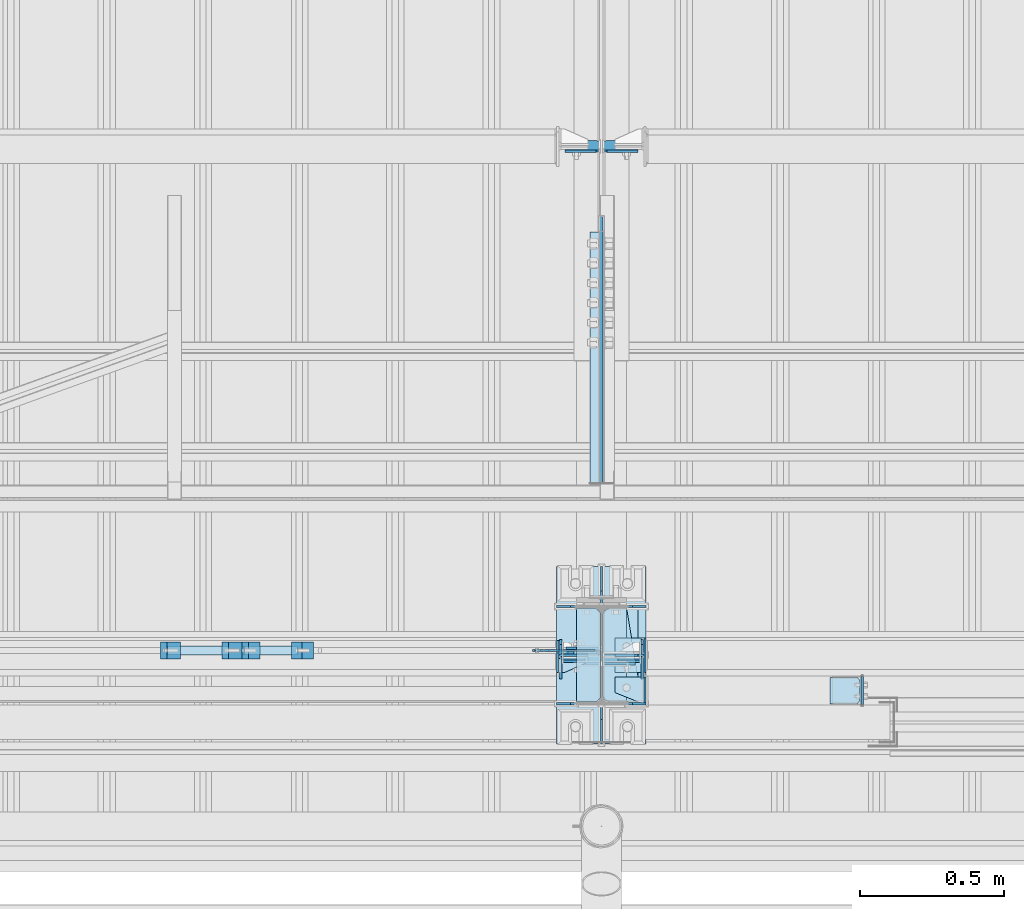
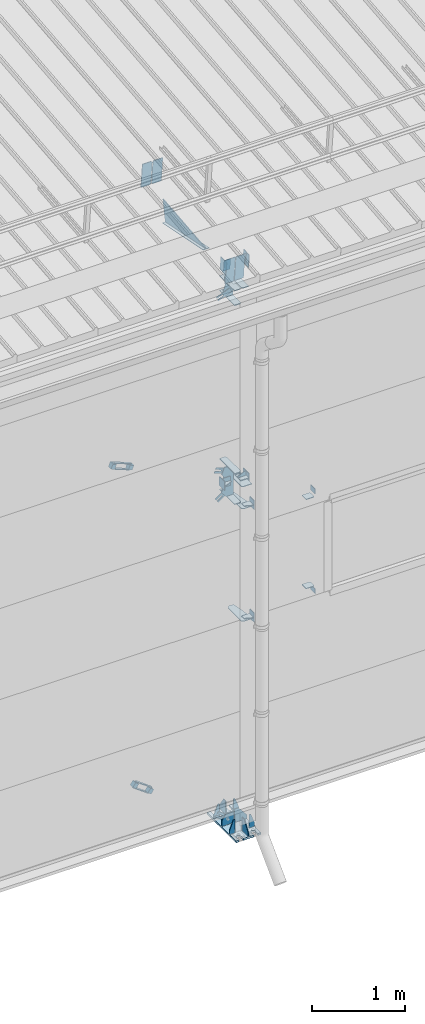
# One storey, part 125 of 709: 55 plates, 4 openings, 15 elements without a shape of their own.
"""IFC4 building model written with IfcOpenShell, lengths in millimetres."""

from ifc_helpers import new_model, si_unit, direction, frame, origin_with_axes, place, context, subcontext, project, spatial, line, arc, indexed_curve, outline, extrude, material, element, aggregate, save


model = new_model("IFC4")

# Units and contexts
model_context = context("Model", 3, precision=0.2, world=origin_with_axes(), true_north=direction((0.0, 1.0)))
body_context = subcontext(model_context, "Body", "Model", "MODEL_VIEW")
ifc_project = project(units=[si_unit("LENGTHUNIT", "METRE", prefix="MILLI"), si_unit("AREAUNIT", "SQUARE_METRE"), si_unit("VOLUMEUNIT", "CUBIC_METRE"), si_unit("MASSUNIT", "GRAM", prefix="KILO"), si_unit("TIMEUNIT", "SECOND"), si_unit("PLANEANGLEUNIT", "RADIAN"), si_unit("SOLIDANGLEUNIT", "STERADIAN"), si_unit("THERMODYNAMICTEMPERATUREUNIT", "DEGREE_CELSIUS"), si_unit("LUMINOUSINTENSITYUNIT", "LUMEN")], contexts=[model_context])

# Site, building, storey
site_placement = place(None, origin_with_axes())
site = spatial("IfcSite", under=ifc_project, at=site_placement, CompositionType="ELEMENT")
building_placement = place(site_placement, origin_with_axes())
building = spatial("IfcBuilding", under=site, at=building_placement, Name="Undefined", CompositionType="ELEMENT")
storey_placement = place(building_placement, origin_with_axes())
storey = spatial("IfcBuildingStorey", under=building, at=storey_placement, Name="Undefined", CompositionType="ELEMENT", Elevation=0.0)

# Assembly, plates
assembly_1_placement = place(storey_placement, frame((28000.0, 346.0, 7089.70002), z_axis=(1.0, 0.0, 0.0), x_axis=(0.0, 0.9950371902, 0.099503719)))
assembly_1 = element("IfcElementAssembly", 1, at=assembly_1_placement, inside=storey)
ifc_material_1 = material(Name="C355-6", Category="STEEL")
plate_1_placement = place(assembly_1_placement, frame((1597.88359, 163.0, 127.0), z_axis=(-1.0, 0.0, 0.0), x_axis=(0.0, 0.0, -1.0)))
plate_1 = element("IfcPlate", 2, at=plate_1_placement, material=ifc_material_1, ObjectType="585", context=body_context, shape_type="SolidModel", body=[
    extrude(outline(indexed_curve([(0.0, 0.0), (108.0, 0.0), (123.0, 15.0), (123.0, 311.0), (108.0, 326.0), (0.0, 326.0)], segments=[line(1, 2, 3, 4, 5, 6, 1)])), frame((0.0, 0.0, 4.0), z_axis=(0.0, 0.0, 1.0), x_axis=(1.0, 0.0, 0.0)), (0.0, 0.0, -1.0), 8.0),
])
plate_2_placement = place(assembly_1_placement, frame((1597.88359, 163.0, -127.0), z_axis=(1.0, 0.0, 0.0), x_axis=(0.0, 0.0, 1.0)))
plate_2 = element("IfcPlate", 3, at=plate_2_placement, material=ifc_material_1, ObjectType="585", context=body_context, shape_type="SolidModel", body=[
    extrude(outline(indexed_curve([(0.0, 0.0), (108.0, 0.0), (123.0, 15.0), (123.0, 311.0), (108.0, 326.0), (0.0, 326.0)], segments=[line(1, 2, 3, 4, 5, 6, 1)])), frame((0.0, 0.0, 4.0), z_axis=(0.0, 0.0, 1.0), x_axis=(1.0, 0.0, 0.0)), (0.0, 0.0, -1.0), 8.0),
])
plate_3_placement = place(assembly_1_placement, frame((1255.8048, -434.94249, -40.0), z_axis=(0.2927142719, 0.9561999556, 0.0), x_axis=(-0.9561999556, 0.2927142719, 0.0)))
plate_3 = element("IfcPlate", 4, at=plate_3_placement, material=ifc_material_1, ObjectType="450", context=body_context, shape_type="SolidModel", body=[
    extrude(outline(indexed_curve([(0.0, 0.0), (887.65935, 0.0), (887.65935, 80.0), (0.0, 80.0)], segments=[line(1, 2, 3, 4, 1)])), frame((0.0, 0.0, 4.0), z_axis=(0.0, 0.0, 1.0), x_axis=(1.0, 0.0, 0.0)), (0.0, 0.0, -1.0), 8.0),
])
plate_4_placement = place(assembly_1_placement, frame((1336.51563, -171.28713, 0.0), z_axis=(0.0, 0.0, 1.0), x_axis=(-1.0, 0.0, 0.0)))
plate_4 = element("IfcPlate", 5, at=plate_4_placement, material=ifc_material_1, ObjectType="449", context=body_context, shape_type="SolidModel", body=[
    extrude(outline(indexed_curve([(0.0, 0.0), (928.3198, 0.0), (79.53997, 259.83056)], segments=[line(1, 2, 3, 1)])), frame((0.0, 0.0, 6.0), z_axis=(0.0, 0.0, 1.0), x_axis=(1.0, 0.0, 0.0)), (0.0, 0.0, -1.0), 12.0),
])
aggregate(assembly_1, [plate_1, plate_2, plate_3, plate_4])

assembly_2_placement = place(storey_placement, frame((22000.0, 173.0, 4310.0), z_axis=(0.0, 0.0, -1.0), x_axis=(1.0, 0.0, 0.0)))
assembly_2 = element("IfcElementAssembly", 6, at=assembly_2_placement, inside=storey)
plate_5_placement = place(assembly_2_placement, frame((5953.0, 60.0, 0.0), z_axis=(0.0, 0.0, -1.0), x_axis=(0.0, -1.0, 0.0)))
plate_5 = element("IfcPlate", 7, at=plate_5_placement, material=ifc_material_1, ObjectType="521", context=body_context, shape_type="SolidModel", body=[
    extrude(outline(indexed_curve([(0.0, 80.0), (36.0, 0.0), (56.0, 0.0), (56.0, 90.0), (46.0, 100.0), (0.0, 100.0)], segments=[line(1, 2, 3, 4, 5, 6, 1)])), frame((0.0, 0.0, 4.0), z_axis=(0.0, 0.0, 1.0), x_axis=(1.0, 0.0, 0.0)), (0.0, 0.0, -1.0), 8.0),
])
plate_6_placement = place(assembly_2_placement, frame((5953.0, 0.0, -60.0), z_axis=(0.0, -1.0, 0.0), x_axis=(0.0, 0.0, 1.0)))
plate_6 = element("IfcPlate", 8, at=plate_6_placement, material=ifc_material_1, ObjectType="520", context=body_context, shape_type="SolidModel", body=[
    extrude(outline(indexed_curve([(0.0, 0.0), (120.0, 0.0), (120.0, 100.0), (0.0, 100.0)], segments=[line(1, 2, 3, 4, 1)])), frame((0.0, 0.0, 4.0), z_axis=(0.0, 0.0, 1.0), x_axis=(1.0, 0.0, 0.0)), (0.0, 0.0, -1.0), 8.0),
])
plate_7_placement = place(assembly_2_placement, frame((5849.0, -50.0, -60.0), z_axis=(1.0, 0.0, 0.0), x_axis=(0.0, 1.0, 0.0)))
plate_7 = element("IfcPlate", 9, at=plate_7_placement, material=ifc_material_1, ObjectType="519", context=body_context, shape_type="SolidModel", body=[
    extrude(outline(indexed_curve([(0.0, 0.0), (110.0, 0.0), (110.0, 120.0), (0.0, 120.0)], segments=[line(1, 2, 3, 4, 1)])), frame((0.0, 0.0, 4.0), z_axis=(0.0, 0.0, 1.0), x_axis=(1.0, 0.0, 0.0)), (0.0, 0.0, -1.0), 8.0),
])
aggregate(assembly_2, [plate_5, plate_6, plate_7])

# Assembly, plate
assembly_3_placement = place(storey_placement, frame((23129.07626, 189.0, 672.76012), z_axis=(0.0, -1.0, 0.0), x_axis=(0.8064830392, 0.0, 0.5912572262)))
assembly_3 = element("IfcElementAssembly", 10, at=assembly_3_placement, inside=storey)
plate_8_placement = place(assembly_3_placement, frame((5781.83429, 35.0, 0.0), z_axis=(0.0, 0.0, -1.0), x_axis=(1.0, 0.0, 0.0)))
plate_8 = element("IfcPlate", 11, at=plate_8_placement, material=ifc_material_1, ObjectType="525", context=body_context, shape_type="SolidModel", body=[
    extrude(outline(indexed_curve([(0.0, 0.0), (200.0, 0.0), (200.0, 70.0), (0.0, 70.0), (0.0, 46.0), (80.0, 46.0), (80.0, 24.0), (0.0, 24.0)], segments=[line(1, 2, 3, 4, 5, 6, 7, 8, 1)])), frame((0.0, 0.0, 4.0), z_axis=(0.0, 0.0, 1.0), x_axis=(1.0, 0.0, 0.0)), (0.0, 0.0, -1.0), 8.0),
])
aggregate(assembly_3, [plate_8])

assembly_4_placement = place(storey_placement, frame((26870.92374, 189.0, 672.76012), z_axis=(0.0, -1.0, 0.0), x_axis=(0.8064830392, 0.0, -0.5912572261)))
assembly_4 = element("IfcElementAssembly", 12, at=assembly_4_placement, inside=storey)
plate_9_placement = place(assembly_4_placement, frame((1145.82155, 11.0, 0.0), z_axis=(0.0, 0.0, 1.0), x_axis=(1.0, 0.0, 0.0)))
plate_9 = element("IfcPlate", 13, at=plate_9_placement, material=ifc_material_1, ObjectType="490", context=body_context, shape_type="SolidModel", body=[
    extrude(outline(indexed_curve([(0.0, 0.0), (80.0, 0.0), (80.0, -22.0), (0.0, -22.0), (0.0, -46.0), (200.0, -46.0), (200.0, 24.0), (0.0, 24.0)], segments=[line(1, 2, 3, 4, 5, 6, 7, 8, 1)])), frame((0.0, 0.0, 4.0), z_axis=(0.0, 0.0, 1.0), x_axis=(1.0, 0.0, 0.0)), (0.0, 0.0, -1.0), 8.0),
])
aggregate(assembly_4, [plate_9])

# Assembly, plates
assembly_5_placement = place(storey_placement, frame((26981.40701, 159.0, 628.96003), z_axis=(-0.8064830392, 0.0, 0.5912572262), x_axis=(0.0, 1.0, 0.0)))
assembly_5 = element("IfcElementAssembly", 14, at=assembly_5_placement, inside=storey)
ifc_material_2 = material(Name="Steel_Undefined", Category="STEEL")
plate_10_placement = place(assembly_5_placement, frame((0.0, 0.0, 230.0), z_axis=(0.0, 0.0, 1.0), x_axis=(1.0, 0.0, 0.0)))
plate_10 = element("IfcPlate", 15, at=plate_10_placement, material=ifc_material_2, ObjectType="483", context=body_context, shape_type="SolidModel", body=[
    extrude(outline(indexed_curve([(0.0, 0.0), (60.0, 0.0), (60.0, 60.0), (0.0, 60.0)], segments=[line(1, 2, 3, 4, 1)])), frame((0.0, 0.0, 25.0), z_axis=(0.0, 0.0, 1.0), x_axis=(1.0, 0.0, 0.0)), (0.0, 0.0, -1.0), 50.0),
])
plate_11_placement = place(assembly_5_placement, frame((15.0, -6.0, 230.0), z_axis=(0.0, 1.0, 0.0), x_axis=(1.0, 0.0, 0.0)))
plate_11 = element("IfcPlate", 16, at=plate_11_placement, material=ifc_material_2, ObjectType="484", context=body_context, shape_type="SolidModel", body=[
    extrude(outline(indexed_curve([(0.0, 0.0), (30.0, 0.0), (30.0, 230.0), (0.0, 230.0)], segments=[line(1, 2, 3, 4, 1)])), frame((0.0, 0.0, 6.0), z_axis=(0.0, 0.0, 1.0), x_axis=(1.0, 0.0, 0.0)), (0.0, 0.0, -1.0), 12.0),
])
plate_12_placement = place(assembly_5_placement, frame((15.0, 66.0, 230.0), z_axis=(0.0, 1.0, 0.0), x_axis=(1.0, 0.0, 0.0)))
plate_12 = element("IfcPlate", 17, at=plate_12_placement, material=ifc_material_2, ObjectType="484", context=body_context, shape_type="SolidModel", body=[
    extrude(outline(indexed_curve([(0.0, 0.0), (30.0, 0.0), (30.0, 230.0), (0.0, 230.0)], segments=[line(1, 2, 3, 4, 1)])), frame((0.0, 0.0, 6.0), z_axis=(0.0, 0.0, 1.0), x_axis=(1.0, 0.0, 0.0)), (0.0, 0.0, -1.0), 12.0),
])
plate_13_placement = place(assembly_5_placement, origin_with_axes())
plate_13 = element("IfcPlate", 18, at=plate_13_placement, material=ifc_material_2, ObjectType="482", context=body_context, shape_type="SolidModel", body=[
    extrude(outline(indexed_curve([(0.0, 0.0), (60.0, 0.0), (60.0, 60.0), (0.0, 60.0)], segments=[line(1, 2, 3, 4, 1)])), frame((0.0, 0.0, 25.0), z_axis=(0.0, 0.0, 1.0), x_axis=(1.0, 0.0, 0.0)), (0.0, 0.0, -1.0), 50.0),
])
aggregate(assembly_5, [plate_10, plate_11, plate_12, plate_13])

# Assembly, plate
assembly_6_placement = place(storey_placement, frame((23387.0491, 189.0, 4959.49238), z_axis=(0.0, -1.0, 0.0), x_axis=(0.9286065, 0.0, 0.371065989)))
assembly_6 = element("IfcElementAssembly", 19, at=assembly_6_placement, inside=storey)
plate_14_placement = place(assembly_6_placement, frame((4750.84953, 11.0, 0.0), z_axis=(0.0, 0.0, 1.0), x_axis=(1.0, 0.0, 0.0)))
plate_14 = element("IfcPlate", 20, at=plate_14_placement, material=ifc_material_1, ObjectType="556", context=body_context, shape_type="SolidModel", body=[
    extrude(outline(indexed_curve([(0.0, 0.0), (80.0, 0.0), (80.0, -22.0), (0.0, -22.0), (0.0, -41.0), (180.0, -41.0), (180.0, 19.0), (0.0, 19.0)], segments=[line(1, 2, 3, 4, 5, 6, 7, 8, 1)])), frame((0.0, 0.0, 4.0), z_axis=(0.0, 0.0, 1.0), x_axis=(1.0, 0.0, 0.0)), (0.0, 0.0, -1.0), 8.0),
])
aggregate(assembly_6, [plate_14])

assembly_7_placement = place(storey_placement, frame((26612.9509, 189.0, 4959.49238), z_axis=(0.0, -1.0, 0.0), x_axis=(0.9286065, 0.0, -0.371065989)))
assembly_7 = element("IfcElementAssembly", 21, at=assembly_7_placement, inside=storey)
plate_15_placement = place(assembly_7_placement, frame((1250.0, 35.0, 0.0), z_axis=(0.0, 0.0, -1.0), x_axis=(1.0, 0.0, 0.0)))
plate_15 = element("IfcPlate", 22, at=plate_15_placement, material=ifc_material_1, ObjectType="525", context=body_context, shape_type="SolidModel", body=[
    extrude(outline(indexed_curve([(0.0, 0.0), (200.0, 0.0), (200.0, 70.0), (0.0, 70.0), (0.0, 46.0), (80.0, 46.0), (80.0, 24.0), (0.0, 24.0)], segments=[line(1, 2, 3, 4, 5, 6, 7, 8, 1)])), frame((0.0, 0.0, 4.0), z_axis=(0.0, 0.0, 1.0), x_axis=(1.0, 0.0, 0.0)), (0.0, 0.0, -1.0), 8.0),
])
aggregate(assembly_7, [plate_15])

# Assembly, plates
assembly_8_placement = place(storey_placement, frame((26730.87263, 159.0, 4944.67799), z_axis=(-0.9286065, 0.0, 0.371065989), x_axis=(0.0, 1.0, 0.0)))
assembly_8 = element("IfcElementAssembly", 23, at=assembly_8_placement, inside=storey)
plate_16_placement = place(assembly_8_placement, origin_with_axes())
plate_16 = element("IfcPlate", 24, at=plate_16_placement, material=ifc_material_2, ObjectType="482", context=body_context, shape_type="SolidModel", body=[
    extrude(outline(indexed_curve([(0.0, 0.0), (60.0, 0.0), (60.0, 60.0), (0.0, 60.0)], segments=[line(1, 2, 3, 4, 1)])), frame((0.0, 0.0, 25.0), z_axis=(0.0, 0.0, 1.0), x_axis=(1.0, 0.0, 0.0)), (0.0, 0.0, -1.0), 50.0),
])
plate_17_placement = place(assembly_8_placement, frame((0.0, 0.0, 230.0), z_axis=(0.0, 0.0, 1.0), x_axis=(1.0, 0.0, 0.0)))
plate_17 = element("IfcPlate", 25, at=plate_17_placement, material=ifc_material_2, ObjectType="483", context=body_context, shape_type="SolidModel", body=[
    extrude(outline(indexed_curve([(0.0, 0.0), (60.0, 0.0), (60.0, 60.0), (0.0, 60.0)], segments=[line(1, 2, 3, 4, 1)])), frame((0.0, 0.0, 25.0), z_axis=(0.0, 0.0, 1.0), x_axis=(1.0, 0.0, 0.0)), (0.0, 0.0, -1.0), 50.0),
])
plate_18_placement = place(assembly_8_placement, frame((15.0, 66.0, 230.0), z_axis=(0.0, 1.0, 0.0), x_axis=(1.0, 0.0, 0.0)))
plate_18 = element("IfcPlate", 26, at=plate_18_placement, material=ifc_material_2, ObjectType="484", context=body_context, shape_type="SolidModel", body=[
    extrude(outline(indexed_curve([(0.0, 0.0), (30.0, 0.0), (30.0, 230.0), (0.0, 230.0)], segments=[line(1, 2, 3, 4, 1)])), frame((0.0, 0.0, 6.0), z_axis=(0.0, 0.0, 1.0), x_axis=(1.0, 0.0, 0.0)), (0.0, 0.0, -1.0), 12.0),
])
plate_19_placement = place(assembly_8_placement, frame((15.0, -6.0, 230.0), z_axis=(0.0, 1.0, 0.0), x_axis=(1.0, 0.0, 0.0)))
plate_19 = element("IfcPlate", 27, at=plate_19_placement, material=ifc_material_2, ObjectType="484", context=body_context, shape_type="SolidModel", body=[
    extrude(outline(indexed_curve([(0.0, 0.0), (30.0, 0.0), (30.0, 230.0), (0.0, 230.0)], segments=[line(1, 2, 3, 4, 1)])), frame((0.0, 0.0, 6.0), z_axis=(0.0, 0.0, 1.0), x_axis=(1.0, 0.0, 0.0)), (0.0, 0.0, -1.0), 12.0),
])
aggregate(assembly_8, [plate_16, plate_17, plate_18, plate_19])

# Assembly, plates, voiding features
assembly_9_placement = place(storey_placement, frame((28000.0, 173.0, -200.0), z_axis=(-1.0, 0.0, 0.0), x_axis=(0.0, 0.0, 1.0)))
assembly_9 = element("IfcElementAssembly", 28, at=assembly_9_placement, inside=storey)
plate_20_placement = place(assembly_9_placement, frame((7434.21546, -30.02526, -3.0), z_axis=(0.099503719, 0.9950371902, 0.0), x_axis=(0.0, 0.0, -1.0)))
plate_20 = element("IfcPlate", 29, at=plate_20_placement, material=ifc_material_1, ObjectType="595", context=body_context, shape_type="SolidModel", body=[
    extrude(outline(indexed_curve([(0.0, 0.0), (114.0, 0.0), (114.0, 332.53554), (0.0, 332.53554)], segments=[line(1, 2, 3, 4, 1)])), frame((0.0, 0.0, 4.0), z_axis=(0.0, 0.0, 1.0), x_axis=(1.0, 0.0, 0.0)), (0.0, 0.0, -1.0), 8.0),
])
plate_21_placement = place(assembly_9_placement, frame((7434.21546, -30.02526, 3.0), z_axis=(-0.099503719, -0.9950371902, 0.0), x_axis=(0.0, 0.0, 1.0)))
plate_21 = element("IfcPlate", 30, at=plate_21_placement, material=ifc_material_1, ObjectType="595", context=body_context, shape_type="SolidModel", body=[
    extrude(outline(indexed_curve([(0.0, 0.0), (114.0, 0.0), (114.0, 333.33554), (0.0, 333.33554)], segments=[line(1, 2, 3, 4, 1)])), frame((0.0, 0.0, 4.0), z_axis=(0.0, 0.0, 1.0), x_axis=(1.0, 0.0, 0.0)), (0.0, 0.0, -1.0), 8.0),
])
plate_22_placement = place(assembly_9_placement, frame((6906.03718, 163.0, 87.0), z_axis=(-1.0, 0.0, 0.0), x_axis=(0.0, 0.0, -1.0)))
plate_22 = element("IfcPlate", 31, at=plate_22_placement, material=ifc_material_1, ObjectType="461", context=body_context, shape_type="SolidModel", body=[
    extrude(outline(indexed_curve([(0.0, 0.0), (68.0, 0.0), (83.0, 15.0), (83.0, 311.0), (68.0, 326.0), (0.0, 326.0)], segments=[line(1, 2, 3, 4, 5, 6, 1)])), frame((0.0, 0.0, 4.0), z_axis=(0.0, 0.0, 1.0), x_axis=(1.0, 0.0, 0.0)), (0.0, 0.0, -1.0), 8.0),
])
plate_23_placement = place(assembly_9_placement, frame((7097.93718, 163.0, 87.0), z_axis=(-1.0, 0.0, 0.0), x_axis=(0.0, 0.0, -1.0)))
plate_23 = element("IfcPlate", 32, at=plate_23_placement, material=ifc_material_1, ObjectType="461", context=body_context, shape_type="SolidModel", body=[
    extrude(outline(indexed_curve([(0.0, 0.0), (68.0, 0.0), (83.0, 15.0), (83.0, 311.0), (68.0, 326.0), (0.0, 326.0)], segments=[line(1, 2, 3, 4, 5, 6, 1)])), frame((0.0, 0.0, 4.0), z_axis=(0.0, 0.0, 1.0), x_axis=(1.0, 0.0, 0.0)), (0.0, 0.0, -1.0), 8.0),
])
plate_24_placement = place(assembly_9_placement, frame((7097.93718, -163.0, -87.0), z_axis=(-1.0, 0.0, 0.0), x_axis=(0.0, 0.0, 1.0)))
plate_24 = element("IfcPlate", 33, at=plate_24_placement, material=ifc_material_1, ObjectType="461", context=body_context, shape_type="SolidModel", body=[
    extrude(outline(indexed_curve([(0.0, 0.0), (68.0, 0.0), (83.0, 15.0), (83.0, 311.0), (68.0, 326.0), (0.0, 326.0)], segments=[line(1, 2, 3, 4, 5, 6, 1)])), frame((0.0, 0.0, 4.0), z_axis=(0.0, 0.0, 1.0), x_axis=(1.0, 0.0, 0.0)), (0.0, 0.0, -1.0), 8.0),
])
plate_25_placement = place(assembly_9_placement, frame((25.0, 0.0, -3.0), z_axis=(0.0, -1.0, 0.0), x_axis=(0.0, 0.0, -1.0)))
plate_25 = element("IfcPlate", 34, at=plate_25_placement, material=ifc_material_1, ObjectType="417", context=body_context, shape_type="SolidModel", body=[
    extrude(outline(indexed_curve([(0.0, 0.0), (152.0, 0.0), (152.0, 50.0), (50.0, 175.0), (0.0, 175.0)], segments=[line(1, 2, 3, 4, 5, 1)])), frame((0.0, 0.0, 4.0), z_axis=(0.0, 0.0, 1.0), x_axis=(1.0, 0.0, 0.0)), (0.0, 0.0, -1.0), 8.0),
])
plate_26_placement = place(assembly_9_placement, frame((12.5, -308.0, 155.0), z_axis=(1.0, 0.0, 0.0), x_axis=(0.0, 0.0, -1.0)))
plate_26 = element("IfcPlate", 35, at=plate_26_placement, material=ifc_material_1, context=body_context, shape_type="SolidModel", body=[
    extrude(outline(indexed_curve([(0.0, 0.0), (310.0, 0.0), (310.0, 616.0), (0.0, 616.0)], segments=[line(1, 2, 3, 4, 1)])), frame((0.0, 0.0, 12.5), z_axis=(0.0, 0.0, 1.0), x_axis=(1.0, 0.0, 0.0)), (0.0, 0.0, -1.0), 25.0),
])
voiding_feature_1_placement = place(plate_26_placement, frame((40.0, 616.0, 0.0), z_axis=(0.0, 0.0, -1.0), x_axis=(1.0, 0.0, 0.0)))
element("IfcVoidingFeature", 36, at=voiding_feature_1_placement, cuts=plate_26, PredefinedType="HOLE", context=body_context, shape_type="SolidModel", body=[
    extrude(outline(indexed_curve([(0.0, 0.0), (50.0, 0.0), (50.0, 60.0), (42.67767, 77.67767), (25.0, 85.0), (25.0, 85.0), (7.32233, 77.67767), (0.0, 60.0)], segments=[line(1, 2, 3), arc(3, 4, 5), line(5, 6), arc(6, 7, 8), line(8, 1)])), frame((0.0, 0.0, 12.5), z_axis=(0.0, 0.0, 1.0), x_axis=(1.0, 0.0, 0.0)), (0.0, 0.0, -1.0), 25.0),
])
voiding_feature_2_placement = place(plate_26_placement, frame((40.0, 0.0, 0.0), z_axis=(0.0, 0.0, 1.0), x_axis=(1.0, 0.0, 0.0)))
element("IfcVoidingFeature", 37, at=voiding_feature_2_placement, cuts=plate_26, PredefinedType="HOLE", context=body_context, shape_type="SolidModel", body=[
    extrude(outline(indexed_curve([(0.0, 0.0), (50.0, 0.0), (50.0, 60.0), (42.67767, 77.67767), (25.0, 85.0), (25.0, 85.0), (7.32233, 77.67767), (0.0, 60.0)], segments=[line(1, 2, 3), arc(3, 4, 5), line(5, 6), arc(6, 7, 8), line(8, 1)])), frame((0.0, 0.0, 12.5), z_axis=(0.0, 0.0, 1.0), x_axis=(1.0, 0.0, 0.0)), (0.0, 0.0, -1.0), 25.0),
])
voiding_feature_3_placement = place(plate_26_placement, frame((270.0, 616.0, 0.0), z_axis=(0.0, 0.0, 1.0), x_axis=(-1.0, 0.0, 0.0)))
element("IfcVoidingFeature", 38, at=voiding_feature_3_placement, cuts=plate_26, PredefinedType="HOLE", context=body_context, shape_type="SolidModel", body=[
    extrude(outline(indexed_curve([(0.0, 0.0), (50.0, 0.0), (50.0, 60.0), (42.67767, 77.67767), (25.0, 85.0), (25.0, 85.0), (7.32233, 77.67767), (0.0, 60.0)], segments=[line(1, 2, 3), arc(3, 4, 5), line(5, 6), arc(6, 7, 8), line(8, 1)])), frame((0.0, 0.0, 12.5), z_axis=(0.0, 0.0, 1.0), x_axis=(1.0, 0.0, 0.0)), (0.0, 0.0, -1.0), 25.0),
])
voiding_feature_4_placement = place(plate_26_placement, frame((270.0, 0.0, 0.0), z_axis=(0.0, 0.0, -1.0), x_axis=(-1.0, 0.0, 0.0)))
element("IfcVoidingFeature", 39, at=voiding_feature_4_placement, cuts=plate_26, PredefinedType="HOLE", context=body_context, shape_type="SolidModel", body=[
    extrude(outline(indexed_curve([(0.0, 0.0), (50.0, 0.0), (50.0, 60.0), (42.67767, 77.67767), (25.0, 85.0), (25.0, 85.0), (7.32233, 77.67767), (0.0, 60.0)], segments=[line(1, 2, 3), arc(3, 4, 5), line(5, 6), arc(6, 7, 8), line(8, 1)])), frame((0.0, 0.0, 12.5), z_axis=(0.0, 0.0, 1.0), x_axis=(1.0, 0.0, 0.0)), (0.0, 0.0, -1.0), 25.0),
])
plate_27_placement = place(assembly_9_placement, frame((25.0, -168.5, 87.0), z_axis=(0.0, 1.0, 0.0), x_axis=(0.0, 0.0, 1.0)))
plate_27 = element("IfcPlate", 40, at=plate_27_placement, material=ifc_material_1, ObjectType="419", context=body_context, shape_type="SolidModel", body=[
    extrude(outline(indexed_curve([(0.0, 0.0), (68.0, 0.0), (68.0, 50.0), (20.0, 175.0), (0.0, 175.0)], segments=[line(1, 2, 3, 4, 5, 1)])), frame((0.0, 0.0, 4.0), z_axis=(0.0, 0.0, 1.0), x_axis=(1.0, 0.0, 0.0)), (0.0, 0.0, -1.0), 8.0),
])
plate_28_placement = place(assembly_9_placement, frame((25.0, 168.5, 87.0), z_axis=(0.0, 1.0, 0.0), x_axis=(0.0, 0.0, 1.0)))
plate_28 = element("IfcPlate", 41, at=plate_28_placement, material=ifc_material_1, ObjectType="419", context=body_context, shape_type="SolidModel", body=[
    extrude(outline(indexed_curve([(0.0, 0.0), (68.0, 0.0), (68.0, 50.0), (20.0, 175.0), (0.0, 175.0)], segments=[line(1, 2, 3, 4, 5, 1)])), frame((0.0, 0.0, 4.0), z_axis=(0.0, 0.0, 1.0), x_axis=(1.0, 0.0, 0.0)), (0.0, 0.0, -1.0), 8.0),
])
plate_29_placement = place(assembly_9_placement, frame((25.0, 168.5, -87.0), z_axis=(0.0, -1.0, 0.0), x_axis=(0.0, 0.0, -1.0)))
plate_29 = element("IfcPlate", 42, at=plate_29_placement, material=ifc_material_1, ObjectType="419", context=body_context, shape_type="SolidModel", body=[
    extrude(outline(indexed_curve([(0.0, 0.0), (68.0, 0.0), (68.0, 50.0), (20.0, 175.0), (0.0, 175.0)], segments=[line(1, 2, 3, 4, 5, 1)])), frame((0.0, 0.0, 4.0), z_axis=(0.0, 0.0, 1.0), x_axis=(1.0, 0.0, 0.0)), (0.0, 0.0, -1.0), 8.0),
])
plate_30_placement = place(assembly_9_placement, frame((25.0, -168.5, -87.0), z_axis=(0.0, -1.0, 0.0), x_axis=(0.0, 0.0, -1.0)))
plate_30 = element("IfcPlate", 43, at=plate_30_placement, material=ifc_material_1, ObjectType="419", context=body_context, shape_type="SolidModel", body=[
    extrude(outline(indexed_curve([(0.0, 0.0), (68.0, 0.0), (68.0, 50.0), (20.0, 175.0), (0.0, 175.0)], segments=[line(1, 2, 3, 4, 5, 1)])), frame((0.0, 0.0, 4.0), z_axis=(0.0, 0.0, 1.0), x_axis=(1.0, 0.0, 0.0)), (0.0, 0.0, -1.0), 8.0),
])
plate_31_placement = place(assembly_9_placement, frame((25.0, 173.0, 0.0), z_axis=(0.0, 0.0, -1.0), x_axis=(0.0, 1.0, 0.0)))
plate_31 = element("IfcPlate", 44, at=plate_31_placement, material=ifc_material_1, ObjectType="418", context=body_context, shape_type="SolidModel", body=[
    extrude(outline(indexed_curve([(0.0, 0.0), (135.0, 0.0), (135.0, 50.0), (50.0, 175.0), (0.0, 175.0)], segments=[line(1, 2, 3, 4, 5, 1)])), frame((0.0, 0.0, 4.0), z_axis=(0.0, 0.0, 1.0), x_axis=(1.0, 0.0, 0.0)), (0.0, 0.0, -1.0), 8.0),
])
plate_32_placement = place(assembly_9_placement, frame((25.0, -173.0, 0.0), z_axis=(0.0, 0.0, 1.0), x_axis=(0.0, -1.0, 0.0)))
plate_32 = element("IfcPlate", 45, at=plate_32_placement, material=ifc_material_1, ObjectType="418", context=body_context, shape_type="SolidModel", body=[
    extrude(outline(indexed_curve([(0.0, 0.0), (135.0, 0.0), (135.0, 50.0), (50.0, 175.0), (0.0, 175.0)], segments=[line(1, 2, 3, 4, 5, 1)])), frame((0.0, 0.0, 4.0), z_axis=(0.0, 0.0, 1.0), x_axis=(1.0, 0.0, 0.0)), (0.0, 0.0, -1.0), 8.0),
])
plate_33_placement = place(assembly_9_placement, frame((99.86739, 6.0, 150.94888), z_axis=(0.0, 1.0, 0.0), x_axis=(0.8064830392, 0.0, -0.5912572261)))
plate_33 = element("IfcPlate", 46, at=plate_33_placement, material=ifc_material_1, ObjectType="551", context=body_context, shape_type="SolidModel", body=[
    extrude(outline(indexed_curve([(0.0, 0.0), (90.0, 0.0), (146.01319, 76.40276), (39.19381, 154.71529), (18.22771, 151.4869), (-60.37928, 44.26588)], segments=[line(1, 2, 3, 4, 5, 6, 1)])), frame((0.0, 0.0, 6.0), z_axis=(0.0, 0.0, 1.0), x_axis=(1.0, 0.0, 0.0)), (0.0, 0.0, -1.0), 12.0),
])
plate_34_placement = place(assembly_9_placement, frame((4700.34059, 10.0, 116.73236), z_axis=(0.0, -1.0, 0.0), x_axis=(-0.9286065, 0.0, 0.371065989)))
plate_34 = element("IfcPlate", 47, at=plate_34_placement, material=ifc_material_1, ObjectType="552", context=body_context, shape_type="SolidModel", body=[
    extrude(outline(indexed_curve([(0.0, 0.0), (90.0, 0.0), (115.55903, 35.1197), (245.56394, 87.06894), (305.02493, 81.82799), (352.68082, 158.17533), (321.98714, 234.98741), (302.49206, 243.35051), (-28.27311, 111.17859), (-36.63622, 91.68351)], segments=[line(1, 2, 3, 4, 5, 6, 7, 8, 9, 10, 1)])), frame((0.0, 0.0, 6.0), z_axis=(0.0, 0.0, 1.0), x_axis=(1.0, 0.0, 0.0)), (0.0, 0.0, -1.0), 12.0),
])
plate_35_placement = place(assembly_9_placement, frame((4308.14541, 163.0, 87.0), z_axis=(-1.0, 0.0, 0.0), x_axis=(0.0, 0.0, -1.0)))
plate_35 = element("IfcPlate", 48, at=plate_35_placement, material=ifc_material_1, ObjectType="554", context=body_context, shape_type="SolidModel", body=[
    extrude(outline(indexed_curve([(0.0, 0.0), (68.0, 0.0), (83.0, 15.0), (83.0, 311.0), (68.0, 326.0), (0.0, 326.0)], segments=[line(1, 2, 3, 4, 5, 6, 1)])), frame((0.0, 0.0, 4.0), z_axis=(0.0, 0.0, 1.0), x_axis=(1.0, 0.0, 0.0)), (0.0, 0.0, -1.0), 8.0),
])
plate_36_placement = place(assembly_9_placement, frame((4706.34059, 163.0, 87.0), z_axis=(-1.0, 0.0, 0.0), x_axis=(0.0, 0.0, -1.0)))
plate_36 = element("IfcPlate", 49, at=plate_36_placement, material=ifc_material_1, ObjectType="553", context=body_context, shape_type="SolidModel", body=[
    extrude(outline(indexed_curve([(0.0, 0.0), (68.0, 0.0), (83.0, 15.0), (83.0, 311.0), (68.0, 326.0), (0.0, 326.0)], segments=[line(1, 2, 3, 4, 5, 6, 1)])), frame((0.0, 0.0, 6.0), z_axis=(0.0, 0.0, 1.0), x_axis=(1.0, 0.0, 0.0)), (0.0, 0.0, -1.0), 12.0),
])
plate_37_placement = place(assembly_9_placement, frame((6931.61775, 23.99306, 97.28783), z_axis=(-5.519e-06, 0.9999998141, -0.00060979), x_axis=(0.9286064751, 0.000231397, 0.3710659791)))
plate_37 = element("IfcPlate", 50, at=plate_37_placement, material=ifc_material_1, Name="PLATE", ObjectType="555", context=body_context, shape_type="SolidModel", body=[
    extrude(outline(indexed_curve([(0.0, 0.0), (70.0, 0.0), (146.9134, 69.78458), (115.74386, 147.78751), (-55.02687, 79.54846), (-23.23974, 0.0)], segments=[line(1, 2, 3, 4, 5, 6, 1)])), frame((0.0, 0.0, 4.0), z_axis=(0.0, 0.0, 1.0), x_axis=(1.0, 0.0, 0.0)), (0.0, 0.0, -1.0), 8.0),
])
plate_38_placement = place(assembly_9_placement, frame((4212.0, -163.0, -4.0), z_axis=(1.0, 0.0, 0.0), x_axis=(0.0, 0.0, -1.0)))
plate_38 = element("IfcPlate", 51, at=plate_38_placement, material=ifc_material_1, ObjectType="543", context=body_context, shape_type="SolidModel", body=[
    extrude(outline(indexed_curve([(0.0, 20.0), (20.0, 0.0), (123.0, 0.0), (123.0, 86.0), (83.0, 326.0), (20.0, 326.0), (0.0, 306.0)], segments=[line(1, 2, 3, 4, 5, 6, 7, 1)])), frame((0.0, 0.0, 4.0), z_axis=(0.0, 0.0, 1.0), x_axis=(1.0, 0.0, 0.0)), (0.0, 0.0, -1.0), 8.0),
])
plate_39_placement = place(assembly_9_placement, frame((2742.0, -163.0, -4.0), z_axis=(1.0, 0.0, 0.0), x_axis=(0.0, 0.0, -1.0)))
plate_39 = element("IfcPlate", 52, at=plate_39_placement, material=ifc_material_1, ObjectType="543", context=body_context, shape_type="SolidModel", body=[
    extrude(outline(indexed_curve([(0.0, 20.0), (20.0, 0.0), (123.0, 0.0), (123.0, 86.0), (83.0, 326.0), (20.0, 326.0), (0.0, 306.0)], segments=[line(1, 2, 3, 4, 5, 6, 7, 1)])), frame((0.0, 0.0, 4.0), z_axis=(0.0, 0.0, 1.0), x_axis=(1.0, 0.0, 0.0)), (0.0, 0.0, -1.0), 8.0),
])
plate_40_placement = place(assembly_9_placement, frame((4502.0, -163.0, -127.0), z_axis=(-1.0, 0.0, 0.0), x_axis=(0.0, 0.0, 1.0)))
plate_40 = element("IfcPlate", 53, at=plate_40_placement, material=ifc_material_1, ObjectType="547", context=body_context, shape_type="SolidModel", body=[
    extrude(outline(indexed_curve([(0.0, 0.0), (108.0, 0.0), (123.0, 15.0), (123.0, 311.0), (108.0, 326.0), (0.0, 326.0)], segments=[line(1, 2, 3, 4, 5, 6, 1)])), frame((0.0, 0.0, 4.0), z_axis=(0.0, 0.0, 1.0), x_axis=(1.0, 0.0, 0.0)), (0.0, 0.0, -1.0), 8.0),
])
aggregate(assembly_9, [plate_20, plate_21, plate_22, plate_23, plate_24, plate_25, plate_26, plate_27, plate_28, plate_29, plate_30, plate_31, plate_32, plate_33, plate_34, plate_35, plate_36, plate_37, plate_38, plate_39, plate_40])

# Assembly, plates
assembly_10_placement = place(storey_placement, frame((28000.0, 50.0, 2550.0), z_axis=(0.0, 0.0, -1.0), x_axis=(1.0, 0.0, 0.0)))
assembly_10 = element("IfcElementAssembly", 54, at=assembly_10_placement, inside=storey)
plate_41_placement = place(assembly_10_placement, frame((151.0, 47.0, -60.0), z_axis=(-1.0, 0.0, 0.0), x_axis=(0.0, -1.0, 0.0)))
plate_41 = element("IfcPlate", 55, at=plate_41_placement, material=ifc_material_1, ObjectType="501", context=body_context, shape_type="SolidModel", body=[
    extrude(outline(indexed_curve([(0.0, 0.0), (94.0, 0.0), (94.0, 120.0), (0.0, 120.0)], segments=[line(1, 2, 3, 4, 1)])), frame((0.0, 0.0, 4.0), z_axis=(0.0, 0.0, 1.0), x_axis=(1.0, 0.0, 0.0)), (0.0, 0.0, -1.0), 8.0),
])
plate_42_placement = place(assembly_10_placement, frame((47.0, 47.0, 0.0), z_axis=(0.0, 0.0, 1.0), x_axis=(0.0, -1.0, 0.0)))
plate_42 = element("IfcPlate", 56, at=plate_42_placement, material=ifc_material_1, ObjectType="502", context=body_context, shape_type="SolidModel", body=[
    extrude(outline(indexed_curve([(0.0, 100.0), (40.0, 0.0), (94.0, 0.0), (94.0, 100.0), (0.0, 100.0)], segments=[line(1, 2, 3, 4, 5, 1)])), frame((0.0, 0.0, 4.0), z_axis=(0.0, 0.0, 1.0), x_axis=(1.0, 0.0, 0.0)), (0.0, 0.0, -1.0), 8.0),
])
plate_43_placement = place(assembly_10_placement, frame((904.0, 50.0, -50.0), z_axis=(-1.0, 0.0, 0.0), x_axis=(0.0, 0.0, -1.0)))
plate_43 = element("IfcPlate", 57, at=plate_43_placement, material=ifc_material_1, ObjectType="509", context=body_context, shape_type="SolidModel", body=[
    extrude(outline(indexed_curve([(0.0, 0.0), (65.0, 0.0), (65.0, 100.0), (0.0, 100.0)], segments=[line(1, 2, 3, 4, 1)])), frame((0.0, 0.0, 4.0), z_axis=(0.0, 0.0, 1.0), x_axis=(1.0, 0.0, 0.0)), (0.0, 0.0, -1.0), 8.0),
])
aggregate(assembly_10, [plate_41, plate_42, plate_43])

assembly_11_placement = place(storey_placement, frame((28000.0, 50.0, 4020.0), z_axis=(0.0, 0.0, -1.0), x_axis=(1.0, 0.0, 0.0)))
assembly_11 = element("IfcElementAssembly", 58, at=assembly_11_placement, inside=storey)
plate_44_placement = place(assembly_11_placement, frame((904.0, -50.0, 50.0), z_axis=(-1.0, 0.0, 0.0), x_axis=(0.0, 0.0, 1.0)))
plate_44 = element("IfcPlate", 59, at=plate_44_placement, material=ifc_material_1, ObjectType="509", context=body_context, shape_type="SolidModel", body=[
    extrude(outline(indexed_curve([(0.0, 0.0), (65.0, 0.0), (65.0, 100.0), (0.0, 100.0)], segments=[line(1, 2, 3, 4, 1)])), frame((0.0, 0.0, 4.0), z_axis=(0.0, 0.0, 1.0), x_axis=(1.0, 0.0, 0.0)), (0.0, 0.0, -1.0), 8.0),
])
plate_45_placement = place(assembly_11_placement, frame((47.0, 47.0, 0.0), z_axis=(0.0, 0.0, 1.0), x_axis=(0.0, -1.0, 0.0)))
plate_45 = element("IfcPlate", 60, at=plate_45_placement, material=ifc_material_1, ObjectType="502", context=body_context, shape_type="SolidModel", body=[
    extrude(outline(indexed_curve([(0.0, 100.0), (40.0, 0.0), (94.0, 0.0), (94.0, 100.0), (0.0, 100.0)], segments=[line(1, 2, 3, 4, 5, 1)])), frame((0.0, 0.0, 4.0), z_axis=(0.0, 0.0, 1.0), x_axis=(1.0, 0.0, 0.0)), (0.0, 0.0, -1.0), 8.0),
])
plate_46_placement = place(assembly_11_placement, frame((151.0, 47.0, -60.0), z_axis=(-1.0, 0.0, 0.0), x_axis=(0.0, -1.0, 0.0)))
plate_46 = element("IfcPlate", 61, at=plate_46_placement, material=ifc_material_1, ObjectType="501", context=body_context, shape_type="SolidModel", body=[
    extrude(outline(indexed_curve([(0.0, 0.0), (94.0, 0.0), (94.0, 120.0), (0.0, 120.0)], segments=[line(1, 2, 3, 4, 1)])), frame((0.0, 0.0, 4.0), z_axis=(0.0, 0.0, 1.0), x_axis=(1.0, 0.0, 0.0)), (0.0, 0.0, -1.0), 8.0),
])
aggregate(assembly_11, [plate_44, plate_45, plate_46])

assembly_12_placement = place(storey_placement, frame((28850.0, 50.0, 2600.0), z_axis=(1.0, 0.0, 0.0), x_axis=(0.0, 0.0, 1.0)))
assembly_12 = element("IfcElementAssembly", 62, at=assembly_12_placement, inside=storey)
plate_47_placement = place(assembly_12_placement, frame((103.0, -46.0, 46.0), z_axis=(-1.0, 0.0, 0.0), x_axis=(0.0, 1.0, 0.0)))
plate_47 = element("IfcPlate", 63, at=plate_47_placement, material=ifc_material_1, ObjectType="510", context=body_context, shape_type="SolidModel", body=[
    extrude(outline(indexed_curve([(0.0, 10.0), (10.0, 0.0), (82.0, 0.0), (92.0, 10.0), (92.0, 104.0), (0.0, 104.0)], segments=[line(1, 2, 3, 4, 5, 6, 1)])), frame((0.0, 0.0, 4.0), z_axis=(0.0, 0.0, 1.0), x_axis=(1.0, 0.0, 0.0)), (0.0, 0.0, -1.0), 8.0),
])
plate_48_placement = place(assembly_12_placement, frame((1267.0, 46.0, 46.0), z_axis=(1.0, 0.0, 0.0), x_axis=(0.0, -1.0, 0.0)))
plate_48 = element("IfcPlate", 64, at=plate_48_placement, material=ifc_material_1, ObjectType="510", context=body_context, shape_type="SolidModel", body=[
    extrude(outline(indexed_curve([(0.0, 10.0), (10.0, 0.0), (82.0, 0.0), (92.0, 10.0), (92.0, 104.0), (0.0, 104.0)], segments=[line(1, 2, 3, 4, 5, 6, 1)])), frame((0.0, 0.0, 4.0), z_axis=(0.0, 0.0, 1.0), x_axis=(1.0, 0.0, 0.0)), (0.0, 0.0, -1.0), 8.0),
])
aggregate(assembly_12, [plate_47, plate_48])

assembly_13_placement = place(storey_placement, frame((28000.0, 173.0, 4310.0), z_axis=(0.0, 0.0, -1.0), x_axis=(1.0, 0.0, 0.0)))
assembly_13 = element("IfcElementAssembly", 65, at=assembly_13_placement, inside=storey)
plate_49_placement = place(assembly_13_placement, frame((151.0, 60.0, 60.0), z_axis=(-1.0, 0.0, 0.0), x_axis=(0.0, 0.0, -1.0)))
plate_49 = element("IfcPlate", 66, at=plate_49_placement, material=ifc_material_1, ObjectType="506", context=body_context, shape_type="SolidModel", body=[
    extrude(outline(indexed_curve([(0.0, 0.0), (120.0, 0.0), (120.0, 120.0), (0.0, 120.0)], segments=[line(1, 2, 3, 4, 1)])), frame((0.0, 0.0, 4.0), z_axis=(0.0, 0.0, 1.0), x_axis=(1.0, 0.0, 0.0)), (0.0, 0.0, -1.0), 8.0),
])
plate_50_placement = place(assembly_13_placement, frame((47.0, 60.0, 0.0), z_axis=(0.0, 0.0, 1.0), x_axis=(0.0, -1.0, 0.0)))
plate_50 = element("IfcPlate", 67, at=plate_50_placement, material=ifc_material_1, ObjectType="507", context=body_context, shape_type="SolidModel", body=[
    extrude(outline(indexed_curve([(0.0, 0.0), (120.0, 0.0), (120.0, 100.0), (0.0, 100.0)], segments=[line(1, 2, 3, 4, 1)])), frame((0.0, 0.0, 4.0), z_axis=(0.0, 0.0, 1.0), x_axis=(1.0, 0.0, 0.0)), (0.0, 0.0, -1.0), 8.0),
])
plate_51_placement = place(assembly_13_placement, frame((47.0, 0.0, -60.0), z_axis=(0.0, 1.0, 0.0), x_axis=(0.0, 0.0, 1.0)))
plate_51 = element("IfcPlate", 68, at=plate_51_placement, material=ifc_material_1, ObjectType="508", context=body_context, shape_type="SolidModel", body=[
    extrude(outline(indexed_curve([(0.0, 80.0), (36.0, 0.0), (56.0, 0.0), (56.0, 90.0), (46.0, 100.0), (0.0, 100.0)], segments=[line(1, 2, 3, 4, 5, 6, 1)])), frame((0.0, 0.0, 4.0), z_axis=(0.0, 0.0, 1.0), x_axis=(1.0, 0.0, 0.0)), (0.0, 0.0, -1.0), 8.0),
])
aggregate(assembly_13, [plate_49, plate_50, plate_51])

assembly_14_placement = place(storey_placement, frame((22000.0, 158.95533, 7154.40952), z_axis=(0.0, 0.9950371902, 0.099503719), x_axis=(1.0, 0.0, 0.0)))
assembly_14 = element("IfcElementAssembly", 69, at=assembly_14_placement, inside=storey)
plate_52_placement = place(assembly_14_placement, frame((5943.0, 72.0, 0.0), z_axis=(0.0, 0.0, 1.0), x_axis=(-1.0, 0.0, 0.0)))
plate_52 = element("IfcPlate", 70, at=plate_52_placement, material=ifc_material_1, ObjectType="597", context=body_context, shape_type="SolidModel", body=[
    extrude(outline(indexed_curve([(0.0, 0.0), (80.0, 0.0), (80.0, 144.0), (0.0, 144.0)], segments=[line(1, 2, 3, 4, 1)])), frame((0.0, 0.0, 4.0), z_axis=(0.0, 0.0, 1.0), x_axis=(1.0, 0.0, 0.0)), (0.0, 0.0, -1.0), 8.0),
])
plate_53_placement = place(assembly_14_placement, frame((5859.0, -87.0, 60.0), z_axis=(1.0, 0.0, 0.0), x_axis=(0.0, 0.0, -1.0)))
plate_53 = element("IfcPlate", 71, at=plate_53_placement, material=ifc_material_1, ObjectType="596", context=body_context, shape_type="SolidModel", body=[
    extrude(outline(indexed_curve([(0.0, 0.0), (120.0, 0.0), (120.0, 174.0), (0.0, 174.0)], segments=[line(1, 2, 3, 4, 1)])), frame((0.0, 0.0, 4.0), z_axis=(0.0, 0.0, 1.0), x_axis=(1.0, 0.0, 0.0)), (0.0, 0.0, -1.0), 8.0),
])
aggregate(assembly_14, [plate_52, plate_53])

assembly_15_placement = place(storey_placement, frame((28000.0, 158.95533, 7154.40952), z_axis=(0.0, 0.9950371902, 0.099503719), x_axis=(1.0, 0.0, 0.0)))
assembly_15 = element("IfcElementAssembly", 72, at=assembly_15_placement, inside=storey)
plate_54_placement = place(assembly_15_placement, frame((141.0, -87.0, -60.0), z_axis=(-1.0, 0.0, 0.0), x_axis=(0.0, 0.0, 1.0)))
plate_54 = element("IfcPlate", 73, at=plate_54_placement, material=ifc_material_1, ObjectType="596", context=body_context, shape_type="SolidModel", body=[
    extrude(outline(indexed_curve([(0.0, 0.0), (120.0, 0.0), (120.0, 174.0), (0.0, 174.0)], segments=[line(1, 2, 3, 4, 1)])), frame((0.0, 0.0, 4.0), z_axis=(0.0, 0.0, 1.0), x_axis=(1.0, 0.0, 0.0)), (0.0, 0.0, -1.0), 8.0),
])
plate_55_placement = place(assembly_15_placement, frame((57.0, -72.0, 0.0), z_axis=(0.0, 0.0, 1.0), x_axis=(1.0, 0.0, 0.0)))
plate_55 = element("IfcPlate", 74, at=plate_55_placement, material=ifc_material_1, ObjectType="597", context=body_context, shape_type="SolidModel", body=[
    extrude(outline(indexed_curve([(0.0, 0.0), (80.0, 0.0), (80.0, 144.0), (0.0, 144.0)], segments=[line(1, 2, 3, 4, 1)])), frame((0.0, 0.0, 4.0), z_axis=(0.0, 0.0, 1.0), x_axis=(1.0, 0.0, 0.0)), (0.0, 0.0, -1.0), 8.0),
])
aggregate(assembly_15, [plate_54, plate_55])

save(model, "model.ifc")
